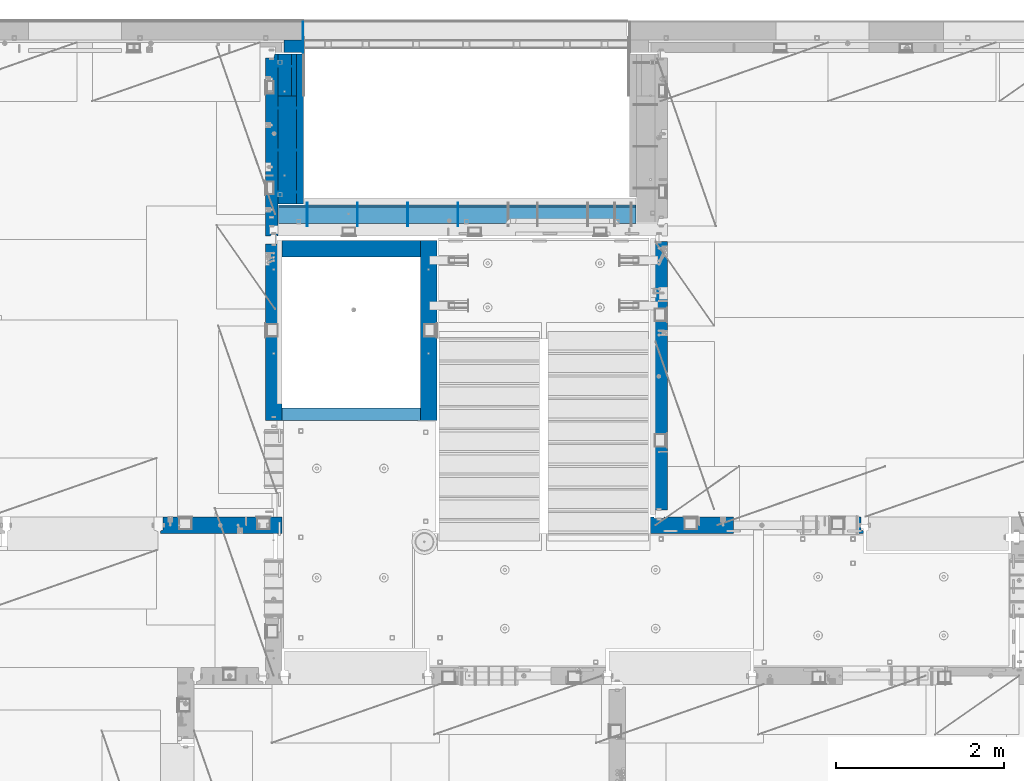
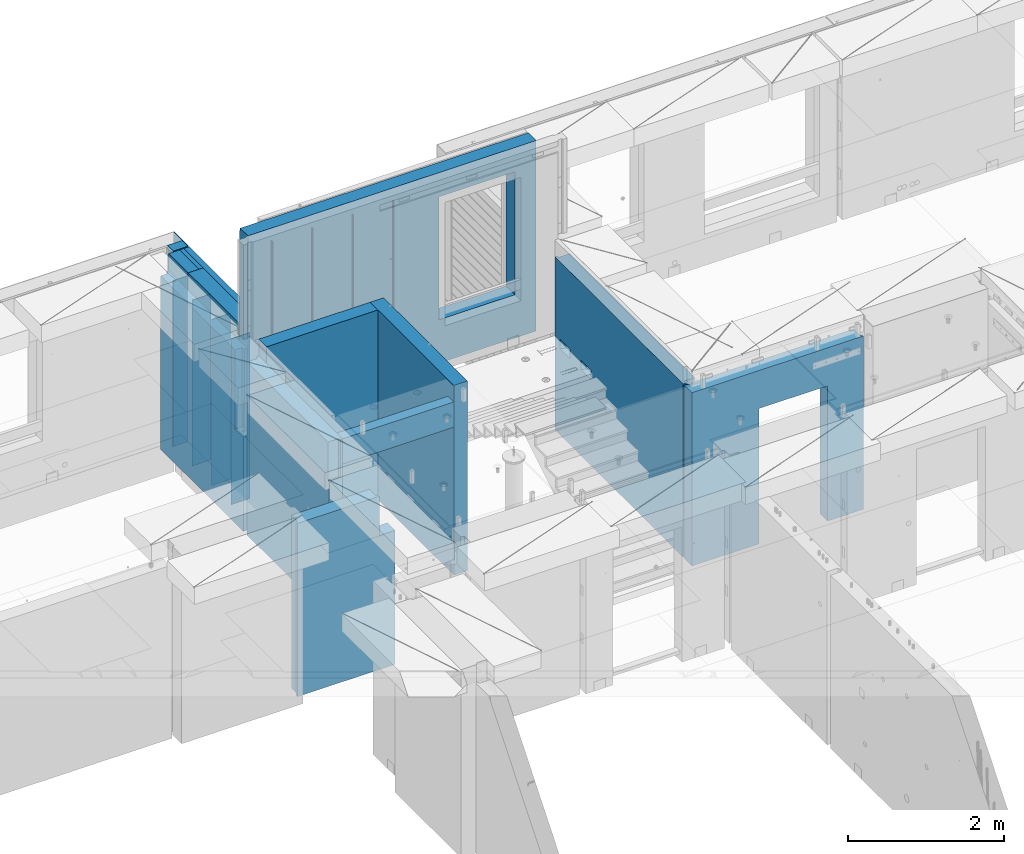
# One storey, part 238 of 350: 23 walls, 8 elements without a shape of their own.
"""IFC2X3 building model written with IfcOpenShell, lengths in millimetres."""

from ifc_helpers import new_model, si_unit, frame, origin_with_axes, place, context, subcontext, project, spatial, faceted_brep, material, type_object, element, aggregate, save


model = new_model("IFC2X3")

# Units and contexts
model_context = context("Model", 3, precision=1e-05, world=origin_with_axes())
body_context = subcontext(model_context, "Body", "Model", "MODEL_VIEW")
ifc_project = project(units=[si_unit("LENGTHUNIT", "METRE", prefix="MILLI"), si_unit("AREAUNIT", "SQUARE_METRE"), si_unit("VOLUMEUNIT", "CUBIC_METRE"), si_unit("MASSUNIT", "GRAM", prefix="KILO"), si_unit("TIMEUNIT", "SECOND"), si_unit("PLANEANGLEUNIT", "RADIAN"), si_unit("SOLIDANGLEUNIT", "STERADIAN"), si_unit("THERMODYNAMICTEMPERATUREUNIT", "DEGREE_CELSIUS"), si_unit("LUMINOUSINTENSITYUNIT", "LUMEN")], contexts=[model_context])

# Site, building, storey
site_placement = place(None, origin_with_axes())
site = spatial("IfcSite", under=ifc_project, at=site_placement, CompositionType="ELEMENT")
building_placement = place(site_placement, origin_with_axes())
building = spatial("IfcBuilding", under=site, at=building_placement, CompositionType="ELEMENT")
storey_placement = place(building_placement, origin_with_axes())
storey = spatial("IfcBuildingStorey", under=building, at=storey_placement, Name="2", CompositionType="ELEMENT", Elevation=0.0)

# Assembly, walls
assembly_1_placement = place(storey_placement, origin_with_axes())
assembly_1 = element("IfcElementAssembly", 1, at=assembly_1_placement, inside=storey, AssemblyPlace="NOTDEFINED", PredefinedType="REINFORCEMENT_UNIT")
ifc_material_1 = material(Name="Undefined")
wall_type_1 = type_object("IfcWallType", PredefinedType="NOTDEFINED")
wall_1_placement = place(assembly_1_placement, frame((17730.0, 20955.0, 86115.0), z_axis=(0.0, 0.0, 1.0), x_axis=(1.0, 0.0, 0.0)))
wall_1 = element("IfcWall", 2, at=wall_1_placement, type_object=wall_type_1, material=ifc_material_1, Name="(PD)", context=body_context, shape_type="Brep", body=[
    faceted_brep([(0.0, 5.0, -1300.0), (0.0, 5.0, 1300.0), (280.0, 5.0, 1300.0), (280.0, 5.0, -1300.0), (0.0, -5.0, 1300.0), (280.0, -5.0, 1300.0), (0.0, -5.0, -1300.0), (280.0, -5.0, -1300.0)], [[[0, 1, 2, 3]], [[1, 4, 5, 2]], [[4, 6, 7, 5]], [[6, 0, 3, 7]], [[5, 7, 3, 2]], [[6, 4, 1, 0]]]),
])
wall_2_placement = place(assembly_1_placement, frame((17730.0, 21455.0, 86115.0), z_axis=(0.0, 0.0, 1.0), x_axis=(1.0, 0.0, 0.0)))
wall_2 = element("IfcWall", 3, at=wall_2_placement, type_object=wall_type_1, material=ifc_material_1, Name="(PD)", context=body_context, shape_type="Brep", body=[
    faceted_brep([(0.0, 5.0, -1300.0), (0.0, 5.0, 1300.0), (280.0, 5.0, 1300.0), (280.0, 5.0, -1300.0), (0.0, -5.0, 1300.0), (280.0, -5.0, 1300.0), (0.0, -5.0, -1300.0), (280.0, -5.0, -1300.0)], [[[0, 1, 2, 3]], [[1, 4, 5, 2]], [[4, 6, 7, 5]], [[6, 0, 3, 7]], [[5, 7, 3, 2]], [[6, 4, 1, 0]]]),
])
wall_3_placement = place(assembly_1_placement, frame((17730.0, 21955.0, 86115.0), z_axis=(0.0, 0.0, 1.0), x_axis=(1.0, 0.0, 0.0)))
wall_3 = element("IfcWall", 4, at=wall_3_placement, type_object=wall_type_1, material=ifc_material_1, Name="(PD)", context=body_context, shape_type="Brep", body=[
    faceted_brep([(0.0, 5.0, -1300.0), (0.0, 5.0, 1300.0), (280.0, 5.0, 1300.0), (280.0, 5.0, -1300.0), (0.0, -5.0, 1300.0), (280.0, -5.0, 1300.0), (0.0, -5.0, -1300.0), (280.0, -5.0, -1300.0)], [[[0, 1, 2, 3]], [[1, 4, 5, 2]], [[4, 6, 7, 5]], [[6, 0, 3, 7]], [[5, 7, 3, 2]], [[6, 4, 1, 0]]]),
])
wall_4_placement = place(assembly_1_placement, frame((17730.0, 22455.0, 86115.0), z_axis=(0.0, 0.0, 1.0), x_axis=(1.0, 0.0, 0.0)))
wall_4 = element("IfcWall", 5, at=wall_4_placement, type_object=wall_type_1, material=ifc_material_1, Name="(PD)", context=body_context, shape_type="Brep", body=[
    faceted_brep([(0.0, 5.0, -1300.0), (0.0, 5.0, 1300.0), (215.0, 5.0, 1300.0), (215.0, 5.0, -1300.0), (0.0, -5.0, 1300.0), (215.0, -5.0, 1300.0), (0.0, -5.0, -1300.0), (215.0, -5.0, -1300.0)], [[[0, 1, 2, 3]], [[1, 4, 5, 2]], [[4, 6, 7, 5]], [[6, 0, 3, 7]], [[5, 7, 3, 2]], [[6, 4, 1, 0]]]),
])

assembly_2_placement = place(storey_placement, origin_with_axes())
assembly_2 = element("IfcElementAssembly", 6, at=assembly_2_placement, inside=storey, AssemblyPlace="NOTDEFINED", PredefinedType="REINFORCEMENT_UNIT")
wall_5_placement = place(assembly_2_placement, frame((18110.0002441406, 20550.0, 87745.0), z_axis=(0.0, 0.0, 1.0), x_axis=(0.0, 1.0, 0.0)))
wall_5 = element("IfcWall", 7, at=wall_5_placement, type_object=wall_type_1, material=ifc_material_1, Name="(PD)", context=body_context, shape_type="Brep", body=[
    faceted_brep([(0.0, 5.0, -1300.0), (0.0, 5.0, 1300.0), (280.0, 5.0, 1300.0), (280.0, 5.0, -1300.0), (0.0, -5.0, 1300.0), (280.0, -5.0, 1300.0), (0.0, -5.0, -1300.0), (280.0, -5.0, -1300.0)], [[[0, 1, 2, 3]], [[1, 4, 5, 2]], [[4, 6, 7, 5]], [[6, 0, 3, 7]], [[5, 7, 3, 2]], [[6, 4, 1, 0]]]),
])
wall_6_placement = place(assembly_2_placement, frame((18710.0002441406, 20550.0, 87745.0), z_axis=(0.0, 0.0, 1.0), x_axis=(0.0, 1.0, 0.0)))
wall_6 = element("IfcWall", 8, at=wall_6_placement, type_object=wall_type_1, material=ifc_material_1, Name="(PD)", context=body_context, shape_type="Brep", body=[
    faceted_brep([(0.0, 5.0, -1300.0), (0.0, 5.0, 1300.0), (280.0, 5.0, 1300.0), (280.0, 5.0, -1300.0), (0.0, -5.0, 1300.0), (280.0, -5.0, 1300.0), (0.0, -5.0, -1300.0), (280.0, -5.0, -1300.0)], [[[0, 1, 2, 3]], [[1, 4, 5, 2]], [[4, 6, 7, 5]], [[6, 0, 3, 7]], [[5, 7, 3, 2]], [[6, 4, 1, 0]]]),
])
wall_7_placement = place(assembly_2_placement, frame((19310.0002441406, 20550.0, 87745.0), z_axis=(0.0, 0.0, 1.0), x_axis=(0.0, 1.0, 0.0)))
wall_7 = element("IfcWall", 9, at=wall_7_placement, type_object=wall_type_1, material=ifc_material_1, Name="(PD)", context=body_context, shape_type="Brep", body=[
    faceted_brep([(0.0, 5.0, -1300.0), (0.0, 5.0, 1300.0), (280.0, 5.0, 1300.0), (280.0, 5.0, -1300.0), (0.0, -5.0, 1300.0), (280.0, -5.0, 1300.0), (0.0, -5.0, -1300.0), (280.0, -5.0, -1300.0)], [[[0, 1, 2, 3]], [[1, 4, 5, 2]], [[4, 6, 7, 5]], [[6, 0, 3, 7]], [[5, 7, 3, 2]], [[6, 4, 1, 0]]]),
])
wall_8_placement = place(assembly_2_placement, frame((19910.0002441406, 20550.0, 87745.0), z_axis=(0.0, 0.0, 1.0), x_axis=(0.0, 1.0, 0.0)))
wall_8 = element("IfcWall", 10, at=wall_8_placement, type_object=wall_type_1, material=ifc_material_1, Name="(PD)", context=body_context, shape_type="Brep", body=[
    faceted_brep([(0.0, 5.0, -1300.0), (0.0, 5.0, 1300.0), (280.0, 5.0, 1300.0), (280.0, 5.0, -1300.0), (0.0, -5.0, 1300.0), (280.0, -5.0, 1300.0), (0.0, -5.0, -1300.0), (280.0, -5.0, -1300.0)], [[[0, 1, 2, 3]], [[1, 4, 5, 2]], [[4, 6, 7, 5]], [[6, 0, 3, 7]], [[5, 7, 3, 2]], [[6, 4, 1, 0]]]),
])

# Assembly, wall
assembly_3_placement = place(storey_placement, origin_with_axes())
assembly_3 = element("IfcElementAssembly", 11, at=assembly_3_placement, inside=storey, AssemblyPlace="NOTDEFINED", PredefinedType="REINFORCEMENT_UNIT")
ifc_material_2 = material(Name="CONCRETE/C25/30")
wall_type_2 = type_object("IfcWallType", PredefinedType="NOTDEFINED")
wall_9_placement = place(assembly_3_placement, frame((22310.0, 16980.0, 86112.5), z_axis=(0.0, 0.0, 1.0), x_axis=(1.0, 0.0, 0.0)))
wall_9 = element("IfcWall", 12, at=wall_9_placement, type_object=wall_type_2, material=ifc_material_2, context=body_context, shape_type="Brep", body=[
    faceted_brep([(890.000686645508, 100.0, 762.5), (890.000686645508, -100.0, 762.5), (890.000686645508, -100.0, -1357.5), (890.000686645508, 100.0, -1357.5), (1910.00068664551, 100.0, 762.5), (1910.00068664551, -100.0, 762.5), (1910.00068664551, 100.0, -1357.5), (1910.00068664551, -100.0, -1357.5), (-100.0, -100.0, -1357.5), (-100.0, -100.0, 1357.5), (-100.0, 100.0, 1357.5), (-100.0, 100.0, -1357.5), (2440.0, -100.0, 1357.5), (2440.0, -100.0, -1357.5), (2440.0, -70.0000000000036, -1357.5), (2440.0, -70.0000000000036, 1357.5), (2410.0, 100.0, 1357.5), (2410.0, -57.0, 1357.5), (2410.0, -57.0, -1357.5), (2410.0, 100.0, -1357.5), (65.0000000000036, 100.0, 1357.5), (52.0, 80.0, 1357.5), (-52.0, 80.0, 1357.5), (-65.0, 100.0, 1357.5), (-65.0, 100.0, -1357.5), (-52.0, 80.0, -1357.5), (52.0, 80.0, -1357.5), (65.0000000000036, 100.0, -1357.5)], [[[0, 1, 2, 3]], [[4, 5, 1, 0]], [[6, 7, 5, 4]], [[8, 9, 10, 11]], [[12, 13, 14, 15]], [[16, 17, 18, 19]], [[15, 14, 18, 17]], [[16, 20, 21, 22, 23, 10, 9, 12, 15, 17]], [[11, 10, 23, 24]], [[22, 25, 24, 23]], [[21, 26, 25, 22]], [[20, 27, 26, 21]], [[8, 11, 24, 25, 26, 27, 3, 2]], [[13, 12, 9, 8, 2, 1, 5, 7]], [[19, 18, 14, 13, 7, 6]], [[3, 27, 20, 16, 19, 6, 4, 0]]]),
])
aggregate(assembly_3, [wall_9])

assembly_4_placement = place(storey_placement, origin_with_axes())
assembly_4 = element("IfcElementAssembly", 13, at=assembly_4_placement, inside=storey, AssemblyPlace="NOTDEFINED", PredefinedType="REINFORCEMENT_UNIT")
wall_10_placement = place(assembly_4_placement, frame((17710.0, 18214.9992663657, 86112.5), z_axis=(0.0, 0.0, 1.0), x_axis=(0.0, 1.0, 0.0)))
wall_10 = element("IfcWall", 14, at=wall_10_placement, type_object=wall_type_2, material=ifc_material_2, context=body_context, shape_type="Brep", body=[
    faceted_brep([(2120.00073363433, -57.0000000000036, 1357.5), (2120.00073363433, -57.0000000000036, -1357.5), (2120.00073363433, 100.0, -1357.5), (2120.00073363433, 100.0, 1357.5), (2165.00073363433, -70.0000000000036, 1357.5), (2165.00073363433, -70.0000000000036, -1357.5), (45.0, 100.0, 1357.5), (45.0, 100.0, 762.5), (45.0, -57.0, 762.5), (45.0, -57.0, 1357.5), (15.0, -70.0, 762.5), (15.0, 100.0, 762.5), (15.0, -70.0, 1357.5), (15.0, 100.0, -1357.5), (15.0, -100.0, -1357.5), (15.0, -100.0, 1357.5), (2165.00073363433, -100.0, -1357.5), (2165.00073363433, -100.0, 1357.5)], [[[0, 1, 2, 3]], [[4, 5, 1, 0]], [[6, 7, 8, 9]], [[10, 8, 7, 11]], [[12, 9, 8, 10]], [[11, 13, 14, 15, 12, 10]], [[15, 14, 16, 17]], [[3, 6, 9, 12, 15, 17, 4, 0]], [[13, 11, 7, 6, 3, 2]], [[16, 14, 13, 2, 1, 5]], [[17, 16, 5, 4]]]),
])

assembly_5_placement = place(storey_placement, origin_with_axes())
assembly_5 = element("IfcElementAssembly", 15, at=assembly_5_placement, inside=storey, AssemblyPlace="NOTDEFINED", PredefinedType="REINFORCEMENT_UNIT")
wall_11_placement = place(assembly_5_placement, frame((22310.0, 16980.0, 86112.5), z_axis=(0.0, 0.0, 1.0), x_axis=(0.0, 1.0, 0.0)))
wall_11 = element("IfcWall", 16, at=wall_11_placement, type_object=wall_type_2, material=ifc_material_2, context=body_context, shape_type="Brep", body=[
    faceted_brep([(3059.9952678883, 0.0998642726626713, 102.5), (3259.9952678883, 0.0998642726626713, 102.5), (3259.9952678883, 0.0998642726626713, -7.5), (3059.9952678883, 0.0998642726626713, -7.5), (3034.9952678883, 100.099864272663, -7.5), (3284.9952678883, 100.099864272663, -7.5), (3034.9952678883, 100.099864272663, 137.5), (3284.9952678883, 100.099864272663, 137.5), (3420.0, 70.0, 1357.5), (3420.0, 100.0, 1357.5), (130.0, 100.0, 1357.5), (130.0, 70.0, 1357.5), (180.0, 57.0, 1357.5), (180.0, -100.0, 1357.5), (3384.99999178648, -100.000000948603, 1357.5), (3385.00000172571, 57.0000007519884, 1357.5), (130.0, 100.0, -1357.5), (130.0, 70.0, -1357.5), (180.0, 57.0, -1357.5), (180.0, -100.0, -1357.5), (3384.99999178648, -100.0, -1357.5), (3385.00000172571, 57.0000007519884, -1357.5), (3420.0, 100.0, -1357.5), (3420.0, 70.0, -1357.5), (2519.9952678883, 0.0998642726626713, 102.5), (2719.9952678883, 0.0998642726626713, 102.5), (2719.9952678883, 0.0998642726626713, -7.5), (2519.9952678883, 0.0998642726626713, -7.5), (2744.9952678883, 100.099864272663, -7.5), (2744.9952678883, 100.099864272663, 137.5), (2494.9952678883, 100.099864272663, -7.5), (2494.9952678883, 100.099864272663, 137.5)], [[[0, 1, 2, 3]], [[4, 3, 2, 5]], [[6, 0, 3, 4]], [[7, 1, 0, 6]], [[5, 2, 1, 7]], [[8, 9, 10, 11, 12, 13, 14, 15]], [[10, 16, 17, 11]], [[11, 17, 18, 12]], [[13, 12, 18, 19]], [[13, 19, 20, 14]], [[14, 20, 21, 15]], [[19, 18, 17, 16, 22, 23, 21, 20]], [[15, 21, 23, 8]], [[22, 9, 8, 23]], [[24, 25, 26, 27]], [[28, 26, 25, 29]], [[30, 27, 26, 28]], [[31, 24, 27, 30]], [[29, 25, 24, 31]], [[16, 10, 9, 22], [4, 5, 7, 6], [30, 28, 29, 31]]]),
])
aggregate(assembly_5, [wall_11])

assembly_6_placement = place(storey_placement, origin_with_axes())
assembly_6 = element("IfcElementAssembly", 17, at=assembly_6_placement, inside=storey, AssemblyPlace="NOTDEFINED", PredefinedType="REINFORCEMENT_UNIT")
wall_12_placement = place(assembly_6_placement, frame((16359.9991042544, 16980.0, 86112.5), z_axis=(0.0, 0.0, 1.0), x_axis=(1.0, 0.0, 0.0)))
wall_12 = element("IfcWall", 18, at=wall_12_placement, type_object=wall_type_2, material=ifc_material_2, context=body_context, shape_type="Brep", body=[
    faceted_brep([(1185.00089736511, 100.0, 1357.5), (1185.00089574558, -57.0, 1357.5), (1185.00089574558, -57.0, 742.5), (1185.00089736511, 99.9999999278843, 742.5), (1220.00089574558, -70.2708332915754, 1357.5), (1220.00089574558, -70.270833291579, 742.5), (1220.00089574558, 100.000001967095, 742.5), (0.0, -100.0, -1357.5), (0.0, -100.0, 1357.5), (0.0, -70.0000178764712, 1357.5), (0.0, -70.0000178764712, -1357.5), (30.0000412533973, -57.0, 1357.5), (30.0000412533973, -57.0, -1357.5), (30.0000000000009, 100.0, 1357.5), (30.0, 100.0, -1357.5), (1450.0, 100.0, -1357.5), (1450.0, -100.0, -1357.5), (1450.00089574558, 100.0, 742.5), (1450.0, -100.0, 742.5), (1220.00089574558, -100.0, 1357.5), (1220.00089574558, -100.0, 742.5), (1225.00089532057, 100.0, 742.5)], [[[0, 1, 2, 3]], [[4, 5, 2, 1]], [[6, 3, 2, 5]], [[7, 8, 9, 10]], [[11, 12, 10, 9]], [[13, 14, 12, 11]], [[15, 16, 7, 10, 12, 14]], [[16, 15, 17, 18]], [[19, 8, 7, 16, 18, 20]], [[17, 21, 6, 5, 20, 18]], [[19, 20, 5, 4]], [[0, 13, 11, 9, 8, 19, 4, 1]], [[21, 17, 15, 14, 13, 0, 3, 6]]]),
])
aggregate(assembly_6, [wall_12])

# Assembly
assembly_7_placement = place(assembly_2_placement, origin_with_axes())
assembly_7 = element("IfcElementAssembly", 19, at=assembly_7_placement, Name="Steel Assembly", AssemblyPlace="NOTDEFINED", PredefinedType="NOTDEFINED")

aggregate(assembly_2, [assembly_7, wall_5, wall_6, wall_7, wall_8])

# Wall
ifc_material_3 = material(Name="COS5gt")
wall_type_3 = type_object("IfcWallType", PredefinedType="NOTDEFINED")
wall_13_placement = place(assembly_7_placement, frame((17765.0, 20690.0, 87747.5), z_axis=(0.0, 0.0, 1.0), x_axis=(1.0, 0.0, 0.0)))
wall_13 = element("IfcWall", 20, at=wall_13_placement, type_object=wall_type_3, material=ifc_material_3, context=body_context, shape_type="Brep", body=[
    faceted_brep([(0.0, -110.0, 1492.5), (4270.0, -110.0, 1492.5), (4270.0, 90.0, 1492.5), (0.0, 90.0, 1492.5), (4270.0, 110.0, 1442.5), (4270.0, 90.0, 1442.5), (4270.0, -110.0, -1492.5), (4270.0, 90.0, -1492.5), (4270.0, 90.0, -1442.5), (4270.0, 110.0, -1442.5), (0.0, 110.0, 1442.5), (0.0, 110.0, -1442.5), (2839.99840497971, 109.999997720995, -802.5), (2839.99840497971, 109.999997720995, -807.5), (2869.99840497971, 109.999997720995, -807.5), (3919.99840497971, 109.999997720995, -807.5), (3949.99840497971, 109.999997720995, -807.5), (3949.99840497971, 109.999997720995, -802.5), (3949.99840497971, 109.999997720995, 1107.5), (2839.99840497971, 109.999997720995, 1107.5), (2834.05245909535, -110.0, 1113.44594588435), (3955.94435086406, -110.0, 1113.44594588435), (2834.05245909535, -110.0, -813.445945884348), (3955.94435086406, -110.0, -813.445945884348), (0.0, -110.0, -1492.5), (0.0, 90.0, -1492.5), (0.0, 90.0, -1442.5), (0.0, 90.0, 1442.5)], [[[0, 1, 2, 3]], [[4, 5, 2, 1, 6, 7, 8, 9]], [[10, 4, 9, 11], [12, 13, 14, 15, 16, 17, 18, 19]], [[20, 19, 18, 21]], [[12, 19, 20, 22, 13]], [[23, 16, 15, 14, 13, 22]], [[21, 18, 17, 16, 23]], [[0, 24, 6, 1], [22, 20, 21, 23]], [[6, 24, 25, 7]], [[7, 25, 26, 8]], [[9, 8, 26, 11]], [[25, 24, 0, 3, 27, 10, 11, 26]], [[2, 5, 27, 3]], [[4, 10, 27, 5]]]),
])

aggregate(assembly_7, [wall_13])

# Assembly, wall
assembly_8_placement = place(storey_placement, origin_with_axes())
assembly_8 = element("IfcElementAssembly", 21, at=assembly_8_placement, inside=storey, AssemblyPlace="NOTDEFINED", PredefinedType="REINFORCEMENT_UNIT")
ifc_material_4 = material()
wall_14_placement = place(assembly_8_placement, frame((17945.0, 22770.0, 86247.5), z_axis=(0.0, 0.0, 1.0), x_axis=(0.0, -1.0, 0.0)))
wall_14 = element("IfcWall", 22, at=wall_14_placement, type_object=wall_type_3, material=ifc_material_4, context=body_context, shape_type="Brep", body=[
    faceted_brep([(0.0, 110.0, -1492.5), (0.0, 110.0, 1492.5), (150.0, 110.0, 1492.5), (150.0, 110.0, -1492.5), (0.0, -110.0, 1492.5), (150.0, -110.0, 1492.5), (0.0, -110.0, -1492.5), (150.0, -110.0, -1492.5)], [[[0, 1, 2, 3]], [[1, 4, 5, 2]], [[4, 6, 7, 5]], [[6, 0, 3, 7]], [[5, 7, 3, 2]], [[6, 4, 1, 0]]]),
])

# Wall
wall_15_placement = place(assembly_1_placement, frame((17870.0, 22105.0, 86247.5), z_axis=(0.0, 0.0, 1.0), x_axis=(0.0, -1.0, 0.0)))
wall_15 = element("IfcWall", 23, at=wall_15_placement, type_object=wall_type_3, material=ifc_material_3, context=body_context, shape_type="Brep", body=[
    faceted_brep([(0.0, 110.0, -1492.5), (0.0, 110.0, 1492.5), (1290.0, 110.0, 1492.5), (1290.0, 110.0, -1492.5), (0.0, -110.0, 1492.5), (1290.0, -110.0, 1492.5), (0.0, -110.0, -1492.5), (1290.0, -110.0, -1492.5)], [[[0, 1, 2, 3]], [[1, 4, 5, 2]], [[4, 6, 7, 5]], [[6, 0, 3, 7]], [[5, 7, 3, 2]], [[6, 4, 1, 0]]]),
])

ifc_material_5 = material(Name="CONCRETE/C30/37")
wall_type_4 = type_object("IfcWallType", PredefinedType="NOTDEFINED")
wall_16_placement = place(assembly_1_placement, frame((18022.5, 22620.0, 86247.5), z_axis=(0.0, 0.0, 1.0), x_axis=(0.0, -1.0, 0.0)))
wall_16 = element("IfcWall", 24, at=wall_16_placement, type_object=wall_type_4, material=ifc_material_5, context=body_context, shape_type="Brep", body=[
    faceted_brep([(15.0, 42.5, 1342.99999994476), (15.0, 32.4999992506928, 1344.9999999992), (1805.0, 32.5, 1345.0), (1805.0, 42.5, 1343.0), (15.0, 32.4999991126933, 1355.00000040043), (1805.0, 32.5, 1355.0), (15.0, 42.5, 1356.99999988925), (1805.0, 42.5, 1357.0), (15.0, 42.5, 1206.99999988925), (1805.0, 42.5, 1207.0), (1805.0, 32.5, 1205.0), (15.0000000000009, 32.4999991126933, 1205.00000040043), (1805.0, 32.5, 1195.0), (15.0000000000009, 32.4999992506928, 1194.9999999992), (15.0, 42.5, 1192.99999994476), (1805.0, 42.5, 1193.0), (1805.0, 42.5, 1057.0), (15.0, 42.5, 1056.99999988925), (1805.0, 32.5, 1055.0), (15.0, 32.4999991126933, 1055.00000040043), (1805.0, 32.5, 1045.0), (15.0, 32.4999992506928, 1044.9999999992), (15.0, 42.5, 1042.99999994476), (1805.0, 42.5, 1043.0), (1805.0, 42.5, 907.0), (15.0, 42.5, 906.999999889245), (1805.0, 32.5, 905.0), (15.0, 32.4999991126933, 905.000000400425), (1805.0, 32.5, 895.0), (15.0, 32.4999992506928, 894.9999999992), (15.0, 42.5, 892.999999944761), (1805.0, 42.5, 893.0), (1805.0, 42.5, 757.0), (15.0, 42.5, 756.999999889245), (1805.0, 32.5, 755.0), (15.0, 32.4999991126933, 755.000000400425), (1805.0, 32.5, 745.0), (15.0, 32.4999992506928, 744.9999999992), (15.0, 42.5, 742.999999944761), (1805.0, 42.5, 743.0), (1805.0, 42.5, 607.0), (15.0, 42.5, 606.999999889245), (1805.0, 32.5, 605.0), (15.0, 32.4999991126933, 605.000000400425), (1805.0, 32.5, 595.0), (15.0, 32.4999992506928, 594.9999999992), (15.0, 42.5, 592.999999944761), (1805.0, 42.5, 593.0), (1805.0, 42.5, 457.0), (15.0, 42.5, 456.999999889245), (1805.0, 32.5, 455.0), (15.0, 32.4999991126933, 455.000000400425), (1805.0, 32.5, 445.0), (15.0, 32.4999992506928, 444.9999999992), (15.0, 42.5, 442.999999944761), (1805.0, 42.5, 443.0), (1805.0, 42.5, 307.0), (15.0, 42.5, 306.999999889245), (1805.0, 32.5, 305.0), (15.0, 32.4999991126933, 305.000000400425), (1805.0, 32.5, 295.0), (15.0, 32.4999992506928, 294.9999999992), (15.0, 42.5, 292.999999944761), (1805.0, 42.5, 293.0), (1805.0, 42.5, 157.0), (15.0, 42.5, 156.999999889245), (1805.0, 32.5, 155.0), (15.0000000000009, 32.4999991126933, 155.000000400425), (1805.0, 32.5, 145.0), (15.0000000000009, 32.4999992506928, 144.9999999992), (15.0, 42.5, 142.999999944761), (1805.0, 42.5, 143.0), (1805.0, 42.5, 7.0), (15.0, 42.5, 6.99999988924537), (1805.0, 32.5, 5.0), (14.9999999999991, 32.4999991126933, 5.00000040042505), (1805.0, 32.5, -5.0), (14.9999999999991, 32.4999992506928, -5.00000000080036), (15.0, 42.5, -7.00000005523907), (1805.0, 42.5, -7.0), (1805.0, 42.5, -143.0), (15.0, 42.5, -143.000000110755), (1805.0, 32.5, -145.0), (15.0000000000009, 32.4999991126933, -144.999999599575), (1805.0, 32.5, -155.0), (15.0000000000009, 32.4999992506928, -155.0000000008), (15.0, 42.5, -157.000000055239), (1805.0, 42.5, -157.0), (1805.0, 42.5, -293.0), (15.0, 42.5, -293.000000110755), (1805.0, 32.5, -295.0), (15.0, 32.4999991126933, -294.999999599575), (1805.0, 32.5, -305.0), (15.0, 32.4999992506928, -305.0000000008), (15.0, 42.5, -307.000000055239), (1805.0, 42.5, -307.0), (1805.0, 42.5, -443.0), (15.0, 42.5, -443.000000110755), (1805.0, 32.5, -445.0), (15.0000000000009, 32.4999991126933, -444.999999599575), (1805.0, 32.5, -455.0), (15.0000000000009, 32.4999992506928, -455.0000000008), (15.0, 42.5, -457.000000055239), (1805.0, 42.5, -457.0), (1805.0, 42.5, -593.0), (15.0, 42.5, -593.000000110755), (1805.0, 32.5, -595.0), (15.0, 32.4999991126933, -594.999999599575), (1805.0, 32.5, -605.0), (15.0, 32.4999992506928, -605.0000000008), (15.0, 42.5, -607.000000055239), (1805.0, 42.5, -607.0), (1805.0, 42.5, -743.0), (15.0, 42.5, -743.000000110755), (1805.0, 32.5, -745.0), (15.0, 32.4999991126933, -744.999999599575), (1805.0, 32.5, -755.0), (15.0, 32.4999992506928, -755.0000000008), (15.0, 42.5, -757.000000055239), (1805.0, 42.5, -757.0), (1805.0, 42.5, -893.0), (15.0, 42.5, -893.000000110755), (1805.0, 32.5, -895.0), (15.0000000000009, 32.4999991126933, -894.999999599575), (1805.0, 32.5, -905.0), (15.0000000000009, 32.4999992506928, -905.0000000008), (15.0, 42.5, -907.000000055239), (1805.0, 42.5, -907.0), (1805.0, 42.5, -1043.0), (15.0, 42.5, -1043.00000011075), (1805.0, 32.5, -1045.0), (15.0, 32.4999991126933, -1044.99999959957), (1805.0, 32.5, -1055.0), (15.0, 32.4999992506928, -1055.0000000008), (15.0, 42.5, -1057.00000005524), (1805.0, 42.5, -1057.0), (1805.0, 42.5, -1193.0), (15.0, 42.5, -1193.00000011075), (1805.0, 32.5, -1195.0), (15.0, 32.4999991126933, -1194.99999959957), (1805.0, 32.5, -1205.0), (15.0, 32.4999992506928, -1205.0000000008), (15.0, 42.5, -1207.00000005524), (1805.0, 42.5, -1207.0), (1805.0, 42.5, -1343.0), (15.0, 42.5, -1343.00000011075), (1805.0, 32.5, -1345.0), (15.0, 32.4999991126933, -1344.99999959957), (1805.0, 32.5, -1355.0), (15.0, 32.4999992506928, -1355.0000000008), (15.0, 42.5, -1357.00000005524), (1805.0, 42.5, -1357.0), (1805.0, 42.5, -1492.5), (15.0, 42.5, -1492.5), (15.0, -42.5, -1492.5), (1805.0, -42.5, -1492.5), (15.0, -42.5, 1492.5), (1805.0, -42.5, 1492.5), (15.0, 42.5, 1492.5), (1805.0, 42.5, 1492.5)], [[[0, 1, 2, 3]], [[4, 5, 2, 1]], [[6, 7, 5, 4]], [[8, 9, 10, 11]], [[11, 10, 12, 13]], [[14, 13, 12, 15]], [[16, 17, 14, 15]], [[17, 16, 18, 19]], [[19, 18, 20, 21]], [[22, 21, 20, 23]], [[24, 25, 22, 23]], [[25, 24, 26, 27]], [[27, 26, 28, 29]], [[30, 29, 28, 31]], [[32, 33, 30, 31]], [[33, 32, 34, 35]], [[35, 34, 36, 37]], [[38, 37, 36, 39]], [[40, 41, 38, 39]], [[41, 40, 42, 43]], [[43, 42, 44, 45]], [[46, 45, 44, 47]], [[48, 49, 46, 47]], [[49, 48, 50, 51]], [[51, 50, 52, 53]], [[54, 53, 52, 55]], [[56, 57, 54, 55]], [[57, 56, 58, 59]], [[59, 58, 60, 61]], [[62, 61, 60, 63]], [[64, 65, 62, 63]], [[65, 64, 66, 67]], [[67, 66, 68, 69]], [[70, 69, 68, 71]], [[72, 73, 70, 71]], [[73, 72, 74, 75]], [[75, 74, 76, 77]], [[78, 77, 76, 79]], [[80, 81, 78, 79]], [[81, 80, 82, 83]], [[83, 82, 84, 85]], [[86, 85, 84, 87]], [[88, 89, 86, 87]], [[89, 88, 90, 91]], [[91, 90, 92, 93]], [[94, 93, 92, 95]], [[96, 97, 94, 95]], [[97, 96, 98, 99]], [[99, 98, 100, 101]], [[102, 101, 100, 103]], [[104, 105, 102, 103]], [[105, 104, 106, 107]], [[107, 106, 108, 109]], [[110, 109, 108, 111]], [[112, 113, 110, 111]], [[113, 112, 114, 115]], [[115, 114, 116, 117]], [[118, 117, 116, 119]], [[120, 121, 118, 119]], [[121, 120, 122, 123]], [[123, 122, 124, 125]], [[126, 125, 124, 127]], [[128, 129, 126, 127]], [[129, 128, 130, 131]], [[131, 130, 132, 133]], [[134, 133, 132, 135]], [[136, 137, 134, 135]], [[137, 136, 138, 139]], [[139, 138, 140, 141]], [[142, 141, 140, 143]], [[144, 145, 142, 143]], [[145, 144, 146, 147]], [[147, 146, 148, 149]], [[150, 149, 148, 151]], [[152, 153, 150, 151]], [[154, 153, 152, 155]], [[156, 154, 155, 157]], [[158, 156, 157, 159]], [[1, 0, 8, 11, 13, 14, 17, 19, 21, 22, 25, 27, 29, 30, 33, 35, 37, 38, 41, 43, 45, 46, 49, 51, 53, 54, 57, 59, 61, 62, 65, 67, 69, 70, 73, 75, 77, 78, 81, 83, 85, 86, 89, 91, 93, 94, 97, 99, 101, 102, 105, 107, 109, 110, 113, 115, 117, 118, 121, 123, 125, 126, 129, 131, 133, 134, 137, 139, 141, 142, 145, 147, 149, 150, 153, 154, 156, 158, 6, 4]], [[9, 8, 0, 3]], [[159, 157, 155, 152, 151, 148, 146, 144, 143, 140, 138, 136, 135, 132, 130, 128, 127, 124, 122, 120, 119, 116, 114, 112, 111, 108, 106, 104, 103, 100, 98, 96, 95, 92, 90, 88, 87, 84, 82, 80, 79, 76, 74, 72, 71, 68, 66, 64, 63, 60, 58, 56, 55, 52, 50, 48, 47, 44, 42, 40, 39, 36, 34, 32, 31, 28, 26, 24, 23, 20, 18, 16, 15, 12, 10, 9, 3, 2, 5, 7]], [[158, 159, 7, 6]]]),
])

wall_type_5 = type_object("IfcWallType", PredefinedType="NOTDEFINED")
wall_17_placement = place(assembly_1_placement, frame((17685.0, 22605.0, 86112.5), z_axis=(0.0, 0.0, 1.0), x_axis=(0.0, -1.0, 0.0)))
wall_17 = element("IfcWall", 25, at=wall_17_placement, type_object=wall_type_5, material=ifc_material_2, context=body_context, shape_type="Brep", body=[
    faceted_brep([(2149.99999999999, -25.0, 117.5), (2149.99999999999, -25.0, 107.5), (2049.99999999999, -25.0, 107.5), (2049.99999999999, -25.0, 117.5), (2149.99999999999, 75.0, 117.5), (2149.99999999999, 75.0, 107.5), (2049.99999999999, 75.0, 107.5), (2049.99999999999, 75.0, 117.5), (2010.000002279, 75.0, 117.5), (2009.99999772087, 75.0, 1357.5), (2009.99999772087, 40.0, 1357.5), (2010.000002279, 40.0, 117.5), (0.0, 40.0, 1357.5), (0.0, 40.0, -1357.5), (50.0, 27.0, -1357.5), (50.0, 27.0, 1357.5), (0.0, 75.0, 1357.5), (0.0, 75.0, -1357.5), (2175.0, 75.0, -1357.5), (2175.0, 75.0, 117.5), (2175.0, 65.0000027843635, 117.5), (2175.0, 65.0000027843635, -1357.5), (2175.0, -75.0, 117.5), (2175.0, -75.0, -1357.5), (2175.0, -15.0000041580934, -1357.5), (2175.0, -15.0000041580934, 117.5), (2154.99999902745, -1.99999787019624, -1357.5), (2154.99999902745, -1.99999787019624, 117.5), (2154.99999873945, 51.9999998754138, -1357.5), (2154.99999873945, 51.9999998754138, 117.5), (50.0, -75.0, -1357.5), (50.0, -75.0, 1357.5), (1959.99999772087, -75.0, 1357.5), (1959.99999772087, 27.0, 1357.5), (1960.0, 27.0, 117.5), (1960.0, -75.0, 117.5), (2025.000002279, -75.0, 117.5), (2010.000002279, -75.0, 117.5), (2025.000002279, 75.0, 117.5)], [[[0, 1, 2, 3]], [[4, 5, 1, 0]], [[6, 2, 1, 5]], [[7, 3, 2, 6]], [[8, 9, 10, 11]], [[12, 13, 14, 15]], [[16, 17, 13, 12]], [[18, 19, 20, 21]], [[22, 23, 24, 25]], [[25, 24, 26, 27]], [[27, 26, 28, 29]], [[20, 29, 28, 21]], [[26, 24, 23, 30, 14, 13, 17, 18, 21, 28]], [[31, 15, 14, 30]], [[32, 33, 10, 9, 16, 12, 15, 31]], [[10, 33, 34, 11]], [[32, 35, 34, 33]], [[31, 30, 23, 22, 36, 37, 35, 32]], [[11, 34, 35, 37]], [[36, 38, 8, 11, 37]], [[5, 4, 19, 18, 17, 16, 9, 8, 38, 7, 6]], [[38, 36, 22, 25, 27, 29, 20, 19, 4, 0, 3, 7]]]),
])

wall_type_6 = type_object("IfcWallType", PredefinedType="NOTDEFINED")
wall_18_placement = place(assembly_4_placement, frame((17809.9999105288, 20280.0000293051, 86242.5), z_axis=(0.0, 0.0, 1.0), x_axis=(1.0, 0.0, 0.0)))
wall_18 = element("IfcWall", 26, at=wall_18_placement, type_object=wall_type_6, material=ifc_material_2, context=body_context, shape_type="Brep", body=[
    faceted_brep([(0.0, 100.0, -1487.5), (0.0, 100.0, 1487.5), (1649.99977111816, 100.0, 1487.5), (1649.99977111816, 100.0, -1487.5), (0.0, -100.0, 1487.5), (1649.99977111816, -100.0, 1487.5), (0.0, -100.0, -1487.5), (1649.99977111816, -100.0, -1487.5)], [[[0, 1, 2, 3]], [[1, 4, 5, 2]], [[4, 6, 7, 5]], [[6, 0, 3, 7]], [[5, 7, 3, 2]], [[6, 4, 1, 0]]]),
])

wall_19_placement = place(assembly_4_placement, frame((19559.999681647, 18229.9992663657, 86242.5), z_axis=(0.0, 0.0, 1.0), x_axis=(0.0, 1.0, 0.0)))
wall_19 = element("IfcWall", 27, at=wall_19_placement, type_object=wall_type_6, material=ifc_material_2, context=body_context, shape_type="Brep", body=[
    faceted_brep([(1470.00546574604, -0.100182625668822, -27.5), (1270.00546574604, -0.100182625668822, -27.5), (1270.00546574604, -0.100182625668822, -137.5), (1470.00546574604, -0.100182625668822, -137.5), (1245.00546574604, -100.100182625669, -137.5), (1245.00546574604, -100.100182625669, 7.5), (1495.00546574604, -100.100182625669, -137.5), (1495.00546574604, -100.100182625669, 7.5), (0.0, -100.0, -1487.5), (0.0, 100.0, -1487.5), (2150.00073363433, 100.0, -1487.5), (2150.00073363433, -100.0, -1487.5), (0.0, -100.0, 1487.5), (0.0, 100.0, 1487.5), (2150.00073363433, -100.0, 1487.5), (2150.00073363433, 100.0, 1487.5), (2010.00546574604, -0.100182625668822, -27.5), (1810.00546574604, -0.100182625668822, -27.5), (1810.00546574604, -0.100182625668822, -137.5), (2010.00546574604, -0.100182625668822, -137.5), (1785.00546574604, -100.100182625669, 7.5), (2035.00546574604, -100.100182625669, 7.5), (1785.00546574604, -100.100182625669, -137.5), (2035.00546574604, -100.100182625669, -137.5)], [[[0, 1, 2, 3]], [[4, 2, 1, 5]], [[6, 3, 2, 4]], [[7, 0, 3, 6]], [[5, 1, 0, 7]], [[8, 9, 10, 11]], [[8, 12, 13, 9]], [[13, 12, 14, 15]], [[9, 13, 15, 10]], [[14, 11, 10, 15]], [[16, 17, 18, 19]], [[20, 17, 16, 21]], [[22, 18, 17, 20]], [[23, 19, 18, 22]], [[21, 16, 19, 23]], [[12, 8, 11, 14], [4, 5, 7, 6], [22, 20, 21, 23]]]),
])

wall_type_7 = type_object("IfcWallType", PredefinedType="NOTDEFINED")
wall_20_placement = place(assembly_4_placement, frame((17809.9999105288, 18304.9992663657, 87272.5), z_axis=(0.0, 0.0, 1.0), x_axis=(1.0, 0.0, 0.0)))
wall_20 = element("IfcWall", 28, at=wall_20_placement, type_object=wall_type_7, material=ifc_material_2, context=body_context, shape_type="Brep", body=[
    faceted_brep([(0.0, 75.0, -197.5), (0.0, 75.0, 197.5), (1649.99961853027, 75.0, 197.5), (1649.99961853027, 75.0, -197.5), (0.0, -75.0, 197.5), (1649.99961853027, -75.0, 197.5), (0.0, -75.0, -197.5), (1649.99961853027, -75.0, -197.5)], [[[0, 1, 2, 3]], [[1, 4, 5, 2]], [[4, 6, 7, 5]], [[6, 0, 3, 7]], [[5, 7, 3, 2]], [[6, 4, 1, 0]]]),
])

aggregate(assembly_4, [wall_18, wall_20, wall_10, wall_19])

ifc_material_6 = material(Name="SPU")
wall_type_8 = type_object("IfcWallType", PredefinedType="NOTDEFINED")
wall_21_placement = place(assembly_1_placement, frame((17840.0, 22605.0, 86247.5), z_axis=(0.0, 0.0, 1.0), x_axis=(0.0, -1.0, 0.0)))
wall_21 = element("IfcWall", 29, at=wall_21_placement, type_object=wall_type_8, material=ifc_material_6, context=body_context, shape_type="Brep", body=[
    faceted_brep([(0.0, 80.0, -1492.5), (0.0, 80.0, 1492.5), (500.0, 80.0, 1492.5), (500.0, 80.0, -1492.5), (0.0, -80.0, 1492.5), (500.0, -80.0, 1492.5), (0.0, -80.0, -1492.5), (500.0, -80.0, -1492.5)], [[[0, 1, 2, 3]], [[1, 4, 5, 2]], [[4, 6, 7, 5]], [[6, 0, 3, 7]], [[5, 7, 3, 2]], [[6, 4, 1, 0]]]),
])

wall_type_9 = type_object("IfcWallType", PredefinedType="NOTDEFINED")
wall_22_placement = place(assembly_1_placement, frame((17950.0, 22620.0, 86247.5), z_axis=(0.0, 0.0, 1.0), x_axis=(0.0, -1.0, 0.0)))
wall_22 = element("IfcWall", 30, at=wall_22_placement, type_object=wall_type_9, material=ifc_material_5, context=body_context, shape_type="Brep", body=[
    faceted_brep([(15.0, 30.0, -1492.5), (15.0, 30.0, 1492.5), (515.0, 30.0, 1492.5), (515.0, 30.0, -1492.5), (15.0, -30.0, 1492.5), (515.0, -30.0, 1492.5), (15.0, -30.0, -1492.5), (515.0, -30.0, -1492.5)], [[[0, 1, 2, 3]], [[1, 4, 5, 2]], [[4, 6, 7, 5]], [[6, 0, 3, 7]], [[5, 7, 3, 2]], [[6, 4, 1, 0]]]),
])

aggregate(assembly_1, [wall_1, wall_2, wall_3, wall_4, wall_21, wall_22, wall_15, wall_16, wall_17])

wall_type_10 = type_object("IfcWallType", PredefinedType="NOTDEFINED")
wall_23_placement = place(assembly_8_placement, frame((18060.0, 22990.0, 86247.5), z_axis=(0.0, 0.0, 1.0), x_axis=(0.0, -1.0, 0.0)))
wall_23 = element("IfcWall", 31, at=wall_23_placement, type_object=wall_type_10, material=ifc_material_5, context=body_context, shape_type="Brep", body=[
    faceted_brep([(0.0, 5.0, -1492.5), (0.0, 5.0, 1492.5), (370.0, 5.0, 1492.5), (370.0, 5.0, -1492.5), (0.0, -5.0, 1492.5), (370.0, -5.0, 1492.5), (0.0, -5.0, -1492.5), (370.0, -5.0, -1492.5)], [[[0, 1, 2, 3]], [[1, 4, 5, 2]], [[4, 6, 7, 5]], [[6, 0, 3, 7]], [[5, 7, 3, 2]], [[6, 4, 1, 0]]]),
])

aggregate(assembly_8, [wall_23, wall_14])

save(model, "model.ifc")
